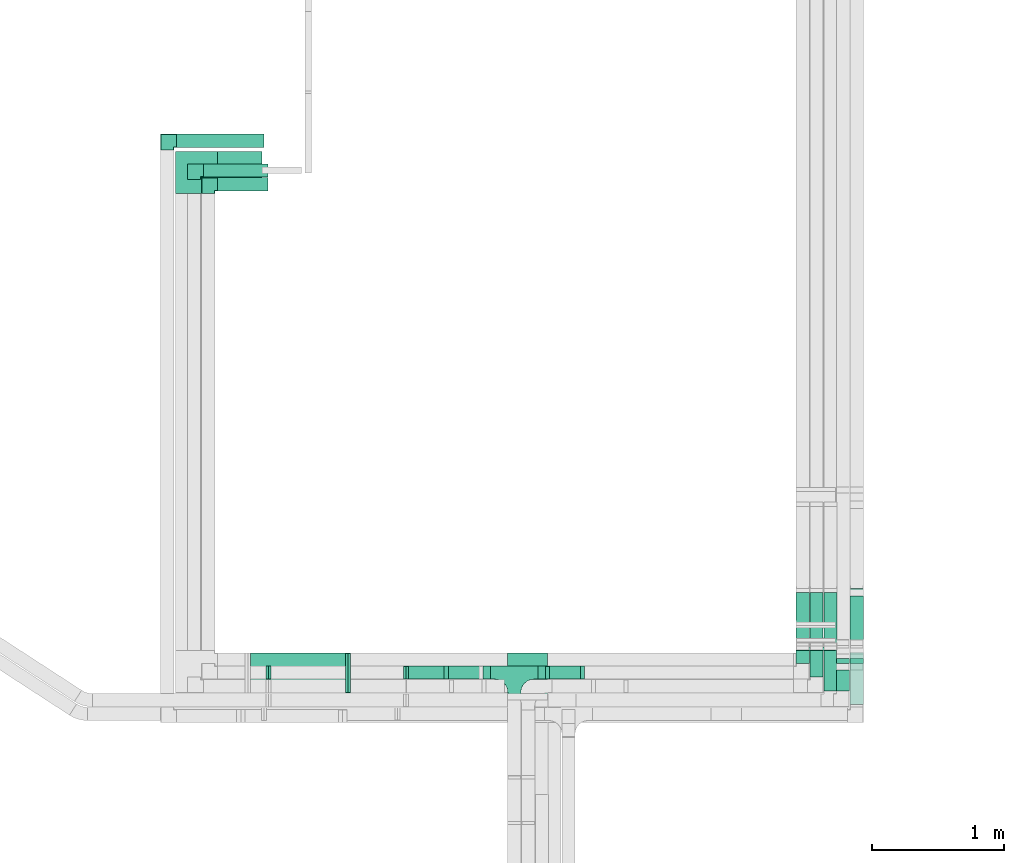
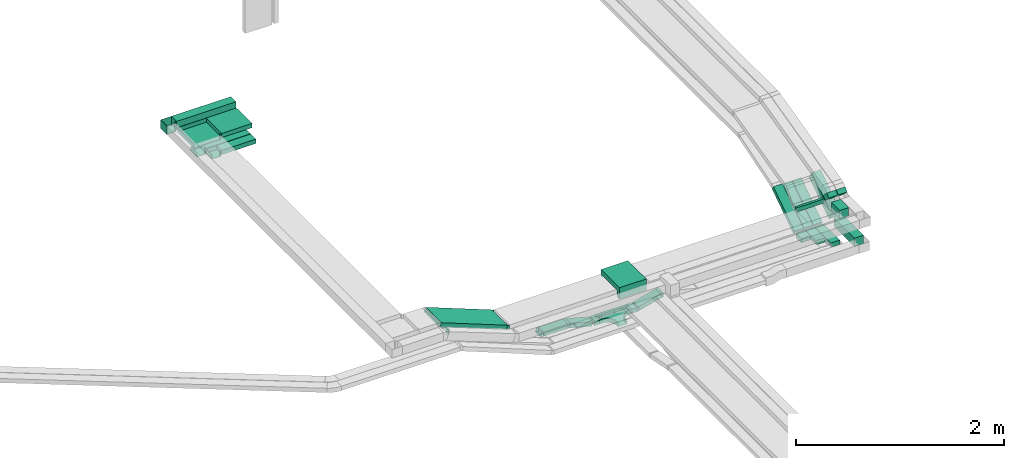
# One storey, part 6 of 14: 22 flow segments, 12 flow fittings.
"""IFC2X3 building model written with IfcOpenShell, lengths in millimetres."""

from ifc_helpers import new_model, entity, si_unit, converted_unit, derived_unit, direction, frame, frame_2d, origin, origin_2d_with_axis, place, context, subcontext, project, spatial, polyline, circle_curve, parameter, trimmed, segment, composite_curve, rectangle, outline, extrude, faceted_brep, source, transform, mapped, material, material_list, type_object, type_shapes, element, save


model = new_model("IFC2X3")

# Units and contexts
model_context = context("Model", 3, precision=0.01, world=origin(), true_north=direction((6.12303176911189e-17, 1.0)))
body_context = subcontext(model_context, "Body", "Model", "MODEL_VIEW")
ifc_project = project(units=[si_unit("LENGTHUNIT", "METRE", prefix="MILLI"), si_unit("AREAUNIT", "SQUARE_METRE"), si_unit("VOLUMEUNIT", "CUBIC_METRE"), converted_unit("PLANEANGLEUNIT", "DEGREE", entity("IfcRatioMeasure", 0.0174532925199433), si_unit("PLANEANGLEUNIT", "RADIAN"), dimensions=[0, 0, 0, 0, 0, 0, 0]), si_unit("MASSUNIT", "GRAM", prefix="KILO"), derived_unit("MASSDENSITYUNIT", [(si_unit("MASSUNIT", "GRAM", prefix="KILO"), 1), (si_unit("LENGTHUNIT", "METRE"), -3)]), derived_unit("MOMENTOFINERTIAUNIT", [(si_unit("LENGTHUNIT", "METRE"), 4)]), si_unit("TIMEUNIT", "SECOND"), si_unit("FREQUENCYUNIT", "HERTZ"), si_unit("THERMODYNAMICTEMPERATUREUNIT", "DEGREE_CELSIUS"), derived_unit("THERMALTRANSMITTANCEUNIT", [(si_unit("MASSUNIT", "GRAM", prefix="KILO"), 1), (si_unit("THERMODYNAMICTEMPERATUREUNIT", "KELVIN"), -1), (si_unit("TIMEUNIT", "SECOND"), -3)]), derived_unit("VOLUMETRICFLOWRATEUNIT", [(si_unit("LENGTHUNIT", "METRE"), 3), (si_unit("TIMEUNIT", "SECOND"), -1)]), derived_unit("MASSFLOWRATEUNIT", [(si_unit("MASSUNIT", "GRAM", prefix="KILO"), 1), (si_unit("TIMEUNIT", "SECOND"), -1)]), derived_unit("ROTATIONALFREQUENCYUNIT", [(si_unit("TIMEUNIT", "SECOND"), -1)]), si_unit("ELECTRICCURRENTUNIT", "AMPERE"), si_unit("ELECTRICVOLTAGEUNIT", "VOLT"), si_unit("POWERUNIT", "WATT"), si_unit("FORCEUNIT", "NEWTON", prefix="KILO"), si_unit("ILLUMINANCEUNIT", "LUX"), si_unit("LUMINOUSFLUXUNIT", "LUMEN"), si_unit("LUMINOUSINTENSITYUNIT", "CANDELA"), derived_unit("USERDEFINED", [(si_unit("MASSUNIT", "GRAM", prefix="KILO"), -1), (si_unit("LENGTHUNIT", "METRE"), -2), (si_unit("TIMEUNIT", "SECOND"), 3), (si_unit("LUMINOUSFLUXUNIT", "LUMEN"), 1)]), derived_unit("LINEARVELOCITYUNIT", [(si_unit("LENGTHUNIT", "METRE"), 1), (si_unit("TIMEUNIT", "SECOND"), -1)]), si_unit("PRESSUREUNIT", "PASCAL"), derived_unit("USERDEFINED", [(si_unit("LENGTHUNIT", "METRE"), -2), (si_unit("MASSUNIT", "GRAM", prefix="KILO"), 1), (si_unit("TIMEUNIT", "SECOND"), -2)]), derived_unit("LINEARFORCEUNIT", [(si_unit("MASSUNIT", "GRAM", prefix="KILO"), 1), (si_unit("LENGTHUNIT", "METRE"), 1), (si_unit("TIMEUNIT", "SECOND"), -2), (si_unit("LENGTHUNIT", "METRE"), -1)]), derived_unit("PLANARFORCEUNIT", [(si_unit("MASSUNIT", "GRAM", prefix="KILO"), 1), (si_unit("LENGTHUNIT", "METRE"), 1), (si_unit("TIMEUNIT", "SECOND"), -2), (si_unit("LENGTHUNIT", "METRE"), -2)])], contexts=[model_context])

# Site, building, storey
site_placement = place(None, origin())
site = spatial("IfcSite", under=ifc_project, at=site_placement, CompositionType="ELEMENT")
building_placement = place(site_placement, origin())
building = spatial("IfcBuilding", under=site, at=building_placement, CompositionType="ELEMENT")
storey_placement = place(building_placement, frame((0.0, 0.0, 19800.0)))
storey = spatial("IfcBuildingStorey", under=building, at=storey_placement, CompositionType="ELEMENT", Elevation=19800.0)

# Flow segments
cable_carrier_segment_type = type_object("IfcCableCarrierSegmentType", PredefinedType="CABLETRAYSEGMENT")
flow_segment_1_placement = place(storey_placement, frame((17256.59, 10152.84, 2600.0)))
element("IfcFlowSegment", 1, at=flow_segment_1_placement, inside=storey, type_object=cable_carrier_segment_type, context=body_context, shape_type="SweptSolid", body=[
    extrude(rectangle(XDim=269.725224847366, YDim=99.9999999999989, at=origin_2d_with_axis()), frame((134.86, 50.0, 0.0)), (0.0, 0.0, 1.0), 49.9999999999973),
])
flow_segment_2_placement = place(storey_placement, frame((20600.22, 9960.23, 2600.0)))
element("IfcFlowSegment", 2, at=flow_segment_2_placement, inside=storey, type_object=cable_carrier_segment_type, context=body_context, shape_type="SweptSolid", body=[
    extrude(rectangle(XDim=396.146721820888, YDim=100.000000000003, at=origin_2d_with_axis()), frame((50.0, 198.07, 0.0), z_axis=(0.0, 0.0, 1.0), x_axis=(0.0, 1.0, 0.0)), (0.0, 0.0, 1.0), 99.9999999999989),
])
flow_segment_3_placement = place(storey_placement, frame((20600.22, 10396.27, 2629.3)))
element("IfcFlowSegment", 3, at=flow_segment_3_placement, inside=storey, type_object=cable_carrier_segment_type, context=body_context, shape_type="SweptSolid", body=[
    extrude(rectangle(XDim=100.000000000001, YDim=467.368346274404, at=frame_2d((0.0, 0.0), x_axis=(0.0, 1.0))), frame((0.0, 221.69, 172.13), z_axis=(1.0, 0.0, 0.0), x_axis=(0.0, 0.829037572555048, 0.559192903470738)), (0.0, 0.0, 1.0), 100.000000000003),
])
flow_segment_4_placement = place(storey_placement, frame((20400.22, 10064.24, 2600.0)))
element("IfcFlowSegment", 4, at=flow_segment_4_placement, inside=storey, type_object=cable_carrier_segment_type, context=body_context, shape_type="SweptSolid", body=[
    extrude(rectangle(XDim=311.24039895918, YDim=100.000000000003, at=origin_2d_with_axis()), frame((50.0, 155.62, 0.0), z_axis=(0.0, 0.0, 1.0), x_axis=(0.0, -1.0, 0.0)), (0.0, 0.0, 1.0), 50.0000000000016),
])
flow_segment_5_placement = place(storey_placement, frame((20400.22, 10401.4, 2616.47)))
element("IfcFlowSegment", 5, at=flow_segment_5_placement, inside=storey, type_object=cable_carrier_segment_type, context=body_context, shape_type="SweptSolid", body=[
    extrude(rectangle(XDim=49.9999999999964, YDim=493.947448455053, at=frame_2d((0.0, 0.0), x_axis=(0.0, 1.0))), frame((0.0, 218.73, 158.83), z_axis=(1.0, 0.0, 0.0), x_axis=(0.0, 0.829037572555015, 0.559192903470787)), (0.0, 0.0, 1.0), 100.000000000003),
])
flow_segment_6_placement = place(storey_placement, frame((20295.22, 10401.4, 2616.47)))
element("IfcFlowSegment", 6, at=flow_segment_6_placement, inside=storey, type_object=cable_carrier_segment_type, context=body_context, shape_type="SweptSolid", body=[
    extrude(rectangle(XDim=49.9999999999977, YDim=493.947448455056, at=frame_2d((0.0, 0.0), x_axis=(0.0, 1.0))), frame((0.0, 218.73, 158.83), z_axis=(1.0, 0.0, 0.0), x_axis=(0.0, 0.829037572555018, 0.559192903470783)), (0.0, 0.0, 1.0), 100.000000000003),
])
flow_segment_7_placement = place(storey_placement, frame((20190.22, 10401.4, 2616.47)))
element("IfcFlowSegment", 7, at=flow_segment_7_placement, inside=storey, type_object=cable_carrier_segment_type, context=body_context, shape_type="SweptSolid", body=[
    extrude(rectangle(XDim=49.9999999999964, YDim=493.947448455053, at=frame_2d((0.0, 0.0), x_axis=(0.0, 1.0))), frame((0.0, 218.73, 158.83), z_axis=(1.0, 0.0, 0.0), x_axis=(0.0, 0.829037572555015, 0.559192903470787)), (0.0, 0.0, 1.0), 100.000000000003),
])
flow_segment_8_placement = place(storey_placement, frame((20295.22, 10169.82, 2600.0)))
element("IfcFlowSegment", 8, at=flow_segment_8_placement, inside=storey, type_object=cable_carrier_segment_type, context=body_context, shape_type="SweptSolid", body=[
    extrude(rectangle(XDim=205.655049876662, YDim=100.000000000003, at=origin_2d_with_axis()), frame((50.0, 102.83, 0.0), z_axis=(0.0, 0.0, 1.0), x_axis=(0.0, -1.0, 0.0)), (0.0, 0.0, 1.0), 49.999999999993),
])
flow_segment_9_placement = place(storey_placement, frame((20190.22, 10272.84, 2600.0)))
element("IfcFlowSegment", 9, at=flow_segment_9_placement, inside=storey, type_object=cable_carrier_segment_type, context=body_context, shape_type="SweptSolid", body=[
    extrude(rectangle(XDim=102.633638913558, YDim=100.000000000003, at=origin_2d_with_axis()), frame((50.0, 51.32, 0.0), z_axis=(0.0, 0.0, 1.0), x_axis=(0.0, 1.0, 0.0)), (0.0, 0.0, 1.0), 49.9999999999973),
])
flow_segment_10_placement = place(storey_placement, frame((20600.22, 10271.78, 2948.93)))
element("IfcFlowSegment", 10, at=flow_segment_10_placement, inside=storey, type_object=cable_carrier_segment_type, context=body_context, shape_type="SweptSolid", body=[
    extrude(rectangle(XDim=53.3220562203544, YDim=99.999999999999, at=origin_2d_with_axis()), frame((0.0, 54.21, 54.21), z_axis=(1.0, 0.0, 0.0), x_axis=(0.0, -0.707106781186487, -0.707106781186608)), (0.0, 0.0, 1.0), 100.000000000003),
])
flow_segment_11_placement = place(storey_placement, frame((20495.22, 10064.24, 2900.0)))
element("IfcFlowSegment", 11, at=flow_segment_11_placement, inside=storey, type_object=cable_carrier_segment_type, context=body_context, shape_type="SweptSolid", body=[
    extrude(rectangle(XDim=160.114335996502, YDim=100.000000000003, at=origin_2d_with_axis()), frame((50.0, 80.06, 0.0), z_axis=(0.0, 0.0, 1.0), x_axis=(0.0, 1.0, 0.0)), (0.0, 0.0, 1.0), 100.000000000003),
])
flow_segment_12_placement = place(storey_placement, frame((20190.22, 10370.13, 2900.0)))
element("IfcFlowSegment", 12, at=flow_segment_12_placement, inside=storey, type_object=cable_carrier_segment_type, context=body_context, shape_type="SweptSolid", body=[
    extrude(rectangle(XDim=28.3940759827228, YDim=300.000000000001, at=origin_2d_with_axis()), frame((150.0, 14.2, 0.0), z_axis=(0.0, 0.0, 1.0), x_axis=(0.0, -1.0, 0.0)), (0.0, 0.0, 1.0), 49.999999999993),
])
flow_segment_13_placement = place(storey_placement, frame((20495.22, 10271.78, 2948.93)))
element("IfcFlowSegment", 13, at=flow_segment_13_placement, inside=storey, type_object=cable_carrier_segment_type, context=body_context, shape_type="SweptSolid", body=[
    extrude(rectangle(XDim=53.322056220356, YDim=100.000000000002, at=origin_2d_with_axis()), frame((0.0, 54.21, 54.21), z_axis=(1.0, 0.0, 0.0), x_axis=(0.0, -0.707106781186507, -0.707106781186588)), (0.0, 0.0, 1.0), 100.000000000008),
])
flow_segment_14_placement = place(storey_placement, frame((18310.63, 10152.84, 2531.55)))
element("IfcFlowSegment", 14, at=flow_segment_14_placement, inside=storey, type_object=cable_carrier_segment_type, context=body_context, shape_type="SweptSolid", body=[
    extrude(rectangle(XDim=49.9999999999963, YDim=99.9999999999989, at=origin_2d_with_axis()), frame((6.47, 50.0, 24.15), z_axis=(0.965925826289085, 0.0, 0.258819045102459), x_axis=(-0.258819045102459, 0.0, 0.965925826289085)), (0.0, 0.0, 1.0), 255.518225265326),
])
flow_segment_15_placement = place(storey_placement, frame((18237.14, 10152.84, 2527.53)))
element("IfcFlowSegment", 15, at=flow_segment_15_placement, inside=storey, type_object=cable_carrier_segment_type, context=body_context, shape_type="SweptSolid", body=[
    extrude(rectangle(XDim=55.8887887634152, YDim=99.9999999999989, at=origin_2d_with_axis()), frame((27.94, 50.0, 0.0), z_axis=(0.0, 0.0, 1.0), x_axis=(-1.0, 0.0, 0.0)), (0.0, 0.0, 1.0), 49.9999999999973),
])
flow_segment_16_placement = place(storey_placement, frame((17543.91, 10152.84, 2531.55)))
element("IfcFlowSegment", 16, at=flow_segment_16_placement, inside=storey, type_object=cable_carrier_segment_type, context=body_context, shape_type="SweptSolid", body=[
    extrude(rectangle(XDim=49.9999999999963, YDim=99.9999999999989, at=frame_2d((0.0, 0.0), x_axis=(0.0, 1.0))), frame((6.47, 50.0, 90.28), z_axis=(0.965925826289085, 0.0, -0.258819045102459), x_axis=(0.0, 1.0, 0.0)), (0.0, 0.0, 1.0), 255.518225265326),
])
flow_segment_17_placement = place(storey_placement, frame((17821.26, 10152.84, 2527.53)))
element("IfcFlowSegment", 17, at=flow_segment_17_placement, inside=storey, type_object=cable_carrier_segment_type, context=body_context, shape_type="SweptSolid", body=[
    extrude(rectangle(XDim=55.8887887635105, YDim=99.9999999999989, at=origin_2d_with_axis()), frame((27.94, 50.0, 0.0)), (0.0, 0.0, 1.0), 49.9999999999973),
])
flow_segment_18_placement = place(storey_placement, frame((16040.11, 10050.13, 2907.31)))
element("IfcFlowSegment", 18, at=flow_segment_18_placement, inside=storey, type_object=cable_carrier_segment_type, context=body_context, shape_type="SweptSolid", body=[
    extrude(rectangle(XDim=49.9999999999997, YDim=300.000000000001, at=frame_2d((0.0, 0.0), x_axis=(0.0, 1.0))), frame((9.1, 150.0, 312.1), z_axis=(0.931412677772554, 0.0, -0.36396486600297), x_axis=(0.0, 1.0, 0.0)), (0.0, 0.0, 1.0), 793.526444095363),
])
flow_segment_19_placement = place(storey_placement, frame((15810.0, 13850.13, 3200.0)))
element("IfcFlowSegment", 19, at=flow_segment_19_placement, inside=storey, type_object=cable_carrier_segment_type, context=body_context, shape_type="SweptSolid", body=[
    extrude(rectangle(XDim=337.305497573283, YDim=300.000000000001, at=origin_2d_with_axis()), frame((168.65, 150.0, 0.0)), (0.0, 0.0, 1.0), 49.9999999999973),
])
flow_segment_20_placement = place(storey_placement, frame((15498.62, 14180.23, 3200.0)))
element("IfcFlowSegment", 20, at=flow_segment_20_placement, inside=storey, type_object=cable_carrier_segment_type, context=body_context, shape_type="SweptSolid", body=[
    extrude(rectangle(XDim=661.375838147948, YDim=99.9999999999989, at=origin_2d_with_axis()), frame((330.69, 50.0, 0.0)), (0.0, 0.0, 1.0), 100.000000000003),
])
flow_segment_21_placement = place(storey_placement, frame((15810.0, 13850.13, 3000.0)))
element("IfcFlowSegment", 21, at=flow_segment_21_placement, inside=storey, type_object=cable_carrier_segment_type, context=body_context, shape_type="SweptSolid", body=[
    extrude(rectangle(XDim=381.506330110017, YDim=99.9999999999989, at=origin_2d_with_axis()), frame((190.75, 50.0, 0.0)), (0.0, 0.0, 1.0), 49.9999999999973),
])
flow_segment_22_placement = place(storey_placement, frame((15701.77, 13954.94, 3000.0)))
element("IfcFlowSegment", 22, at=flow_segment_22_placement, inside=storey, type_object=cable_carrier_segment_type, context=body_context, shape_type="SweptSolid", body=[
    extrude(rectangle(XDim=489.733815594426, YDim=99.9999999999989, at=origin_2d_with_axis()), frame((244.87, 50.0, 0.0)), (0.0, 0.0, 1.0), 49.9999999999973),
])

# Flow fittings
ifc_material = material()
cable_carrier_fitting_type_1 = type_object("IfcCableCarrierFittingType", PredefinedType="NOTDEFINED", material=ifc_material)
shared_shape_1 = source(origin(), body_context, "Body", "Brep", [
    faceted_brep([(-53.41, -124.12, 25.0), (-50.0, -150.0, 25.0), (-50.0, -180.0, 25.0), (-49.2, -180.0, 25.0), (-49.2, -150.0, 25.0), (-52.63, -123.91, 25.0), (-62.7, -99.6, 25.0), (-78.72, -78.72, 25.0), (-99.6, -62.7, 25.0), (-123.91, -52.63, 25.0), (-150.0, -49.2, 25.0), (-180.0, -49.2, 25.0), (-180.0, -50.0, 25.0), (-150.0, -50.0, 25.0), (-124.12, -53.41, 25.0), (-100.0, -63.4, 25.0), (-79.29, -79.29, 25.0), (-63.4, -100.0, 25.0), (180.0, -50.0, 25.0), (180.0, -49.2, 25.0), (150.0, -49.2, 25.0), (123.91, -52.63, 25.0), (99.6, -62.7, 25.0), (78.72, -78.72, 25.0), (62.7, -99.6, 25.0), (52.63, -123.91, 25.0), (49.2, -150.0, 25.0), (49.2, -180.0, 25.0), (50.0, -180.0, 25.0), (50.0, -150.0, 25.0), (53.41, -124.12, 25.0), (63.4, -100.0, 25.0), (79.29, -79.29, 25.0), (100.0, -63.4, 25.0), (124.12, -53.41, 25.0), (150.0, -50.0, 25.0), (180.0, 49.2, 25.0), (180.0, 50.0, 25.0), (-180.0, 50.0, 25.0), (-180.0, 49.2, 25.0), (-180.0, -50.0, -25.0), (-180.0, 50.0, -25.0), (180.0, 50.0, -25.0), (180.0, -50.0, -25.0), (150.0, -50.0, -25.0), (124.12, -53.41, -25.0), (100.0, -63.4, -25.0), (79.29, -79.29, -25.0), (63.4, -100.0, -25.0), (53.41, -124.12, -25.0), (50.0, -150.0, -25.0), (50.0, -180.0, -25.0), (-50.0, -180.0, -25.0), (-50.0, -150.0, -25.0), (-53.41, -124.12, -25.0), (-63.4, -100.0, -25.0), (-79.29, -79.29, -25.0), (-100.0, -63.4, -25.0), (-124.12, -53.41, -25.0), (-150.0, -50.0, -25.0), (-50.0, -150.0, -24.2), (49.2, -180.0, -24.2), (-49.2, -180.0, -24.2), (-49.2, -150.0, -24.2), (-150.0, -49.2, -24.2), (-180.0, -49.2, -24.2), (180.0, -49.2, -24.2), (150.0, -49.2, -24.2), (-180.0, 49.2, -24.2), (-150.0, -50.0, -24.2), (150.0, -50.0, -24.2), (180.0, 49.2, -24.2), (49.2, -150.0, -24.2), (50.0, -150.0, -24.2), (-123.91, -52.63, -24.2), (-99.6, -62.7, -24.2), (-78.72, -78.72, -24.2), (-62.7, -99.6, -24.2), (-52.63, -123.91, -24.2), (52.63, -123.91, -24.2), (62.7, -99.6, -24.2), (78.72, -78.72, -24.2), (99.6, -62.7, -24.2), (123.91, -52.63, -24.2)], [[[0, 1, 2, 3, 4, 5, 6, 7, 8, 9, 10, 11, 12, 13, 14, 15, 16, 17]], [[18, 19, 20, 21, 22, 23, 24, 25, 26, 27, 28, 29, 30, 31, 32, 33, 34, 35]], [[36, 37, 38, 39]], [[40, 41, 42, 43, 44, 45, 46, 47, 48, 49, 50, 51, 52, 53, 54, 55, 56, 57, 58, 59]], [[2, 1, 60, 53, 52]], [[3, 2, 52, 51, 28, 27, 61, 62]], [[4, 3, 62, 63]], [[11, 10, 64, 65]], [[20, 19, 66, 67]], [[39, 38, 41, 40, 12, 11, 65, 68]], [[13, 12, 40, 59, 69]], [[18, 35, 70, 44, 43]], [[19, 18, 43, 42, 37, 36, 71, 66]], [[27, 26, 72, 61]], [[29, 28, 51, 50, 73]], [[38, 37, 42, 41]], [[36, 39, 68, 71]], [[68, 65, 64, 74, 75, 76, 77, 78, 63, 62, 61, 72, 79, 80, 81, 82, 83, 67, 66, 71]], [[14, 13, 69, 59, 58]], [[58, 57, 15, 14]], [[15, 57, 56, 16]], [[0, 17, 55, 54]], [[0, 54, 53, 60, 1]], [[55, 17, 16, 56]], [[5, 4, 63, 78]], [[6, 5, 78, 77]], [[7, 6, 77, 76]], [[8, 7, 76, 75]], [[9, 8, 75, 74]], [[10, 9, 74, 64]], [[21, 20, 67, 83]], [[22, 21, 83, 82]], [[23, 22, 82, 81]], [[81, 80, 24, 23]], [[24, 80, 79, 25]], [[79, 72, 26, 25]], [[30, 29, 73, 50, 49]], [[31, 30, 49, 48]], [[31, 48, 47, 32]], [[33, 32, 47, 46]], [[45, 34, 33, 46]], [[34, 45, 44, 70, 35]]]),
])
type_shapes(cable_carrier_fitting_type_1, [shared_shape_1])
flow_fitting_1_placement = place(storey_placement, frame((18057.14, 10202.84, 2552.53)))
element("IfcFlowFitting", 23, at=flow_fitting_1_placement, inside=storey, type_object=cable_carrier_fitting_type_1, material=ifc_material, Name="470_DKC_S5_T", context=body_context, shape_type="MappedRepresentation", body=[
    mapped(shared_shape_1, transform((0.0, 0.0, 0.0), scale=1.0)),
])
cable_carrier_fitting_type_2 = type_object("IfcCableCarrierFittingType", PredefinedType="NOTDEFINED", material=ifc_material)
shared_shape_2 = source(origin(), body_context, "Body", "Brep", [
    faceted_brep([(-70.0, 50.0, -25.0), (-70.0, -50.0, -25.0), (-70.0, -50.0, 25.0), (-70.0, -47.46, 25.0), (-70.0, -47.46, -22.46), (-70.0, 47.46, -22.46), (-70.0, 47.46, 25.0), (-70.0, 50.0, 25.0), (-50.0, 50.0, -25.0), (-50.0, 70.0, -25.0), (50.0, 70.0, -25.0), (50.0, -50.0, -25.0), (50.0, -50.0, 25.0), (50.0, 70.0, 25.0), (47.46, 70.0, 25.0), (47.46, -47.46, 25.0), (47.46, -47.46, -22.46), (47.46, 70.0, -22.46), (-47.46, 70.0, -22.46), (-47.46, 47.46, -22.46), (-47.46, 47.46, 25.0), (-47.46, 70.0, 25.0), (-50.0, 70.0, 25.0), (-50.0, 50.0, 25.0)], [[[0, 1, 2, 3, 4, 5, 6, 7]], [[1, 0, 8, 9, 10, 11]], [[2, 1, 11, 12]], [[3, 2, 12, 13, 14, 15]], [[4, 3, 15, 16]], [[5, 4, 16, 17, 18, 19]], [[6, 5, 19, 20]], [[7, 6, 20, 21, 22, 23]], [[0, 7, 23, 8]], [[9, 22, 21, 18, 17, 14, 13, 10]], [[12, 11, 10, 13]], [[16, 15, 14, 17]], [[20, 19, 18, 21]], [[8, 23, 22, 9]]]),
])
type_shapes(cable_carrier_fitting_type_2, [shared_shape_2])
for number, where, z_axis, x_axis in (
    (24, (15740.0, 13900.13, 3025.0), (0.0, 0.0, 1.0), (-1.0, 0.0, 0.0)),
    (25, (15631.77, 14004.94, 3025.0), (0.0, 0.0, 1.0), (-1.0, 0.0, 0.0)),
):
    element("IfcFlowFitting", number, at=place(storey_placement, frame(where, z_axis=z_axis, x_axis=x_axis)), inside=storey, type_object=cable_carrier_fitting_type_2, material=ifc_material, context=body_context, shape_type="MappedRepresentation", body=[
        mapped(shared_shape_2, transform((0.0, 0.0, 0.0), scale=1.0)),
    ])
cable_carrier_fitting_type_3 = type_object("IfcCableCarrierFittingType", PredefinedType="NOTDEFINED", material=ifc_material)
shared_shape_3 = source(origin(), body_context, "Body", "Brep", [
    faceted_brep([(-170.0, 150.0, -25.0), (-170.0, -150.0, -25.0), (-170.0, -150.0, 25.0), (-170.0, -147.46, 25.0), (-170.0, -147.46, -22.46), (-170.0, 147.46, -22.46), (-170.0, 147.46, 25.0), (-170.0, 150.0, 25.0), (-150.0, 150.0, -25.0), (-150.0, 170.0, -25.0), (150.0, 170.0, -25.0), (150.0, -150.0, -25.0), (150.0, -150.0, 25.0), (150.0, 170.0, 25.0), (147.46, 170.0, 25.0), (147.46, -147.46, 25.0), (147.46, -147.46, -22.46), (147.46, 170.0, -22.46), (-147.46, 170.0, -22.46), (-147.46, 147.46, -22.46), (-147.46, 147.46, 25.0), (-147.46, 170.0, 25.0), (-150.0, 170.0, 25.0), (-150.0, 150.0, 25.0)], [[[0, 1, 2, 3, 4, 5, 6, 7]], [[1, 0, 8, 9, 10, 11]], [[2, 1, 11, 12]], [[3, 2, 12, 13, 14, 15]], [[4, 3, 15, 16]], [[5, 4, 16, 17, 18, 19]], [[6, 5, 19, 20]], [[7, 6, 20, 21, 22, 23]], [[0, 7, 23, 8]], [[9, 22, 21, 18, 17, 14, 13, 10]], [[12, 11, 10, 13]], [[16, 15, 14, 17]], [[20, 19, 18, 21]], [[8, 23, 22, 9]]]),
])
type_shapes(cable_carrier_fitting_type_3, [shared_shape_3])
flow_fitting_2_placement = place(storey_placement, frame((15640.0, 14000.13, 3225.0), z_axis=(0.0, 0.0, 1.0), x_axis=(-1.0, 0.0, 0.0)))
element("IfcFlowFitting", 26, at=flow_fitting_2_placement, inside=storey, type_object=cable_carrier_fitting_type_3, material=ifc_material, context=body_context, shape_type="MappedRepresentation", body=[
    mapped(shared_shape_3, transform((0.0, 0.0, 0.0), scale=1.0)),
])
cable_carrier_fitting_type_4 = type_object("IfcCableCarrierFittingType", PredefinedType="NOTDEFINED", material=ifc_material)
shared_shape_4 = source(origin(), body_context, "Body", "Brep", [
    faceted_brep([(-70.0, 50.0, -50.0), (-70.0, -50.0, -50.0), (-70.0, -50.0, 50.0), (-70.0, -47.46, 50.0), (-70.0, -47.46, -47.46), (-70.0, 47.46, -47.46), (-70.0, 47.46, 50.0), (-70.0, 50.0, 50.0), (-50.0, 50.0, -50.0), (-50.0, 70.0, -50.0), (50.0, 70.0, -50.0), (50.0, -50.0, -50.0), (50.0, -50.0, 50.0), (50.0, 70.0, 50.0), (47.46, 70.0, 50.0), (47.46, -47.46, 50.0), (47.46, -47.46, -47.46), (47.46, 70.0, -47.46), (-47.46, 70.0, -47.46), (-47.46, 47.46, -47.46), (-47.46, 47.46, 50.0), (-47.46, 70.0, 50.0), (-50.0, 70.0, 50.0), (-50.0, 50.0, 50.0)], [[[0, 1, 2, 3, 4, 5, 6, 7]], [[1, 0, 8, 9, 10, 11]], [[2, 1, 11, 12]], [[3, 2, 12, 13, 14, 15]], [[4, 3, 15, 16]], [[5, 4, 16, 17, 18, 19]], [[6, 5, 19, 20]], [[7, 6, 20, 21, 22, 23]], [[0, 7, 23, 8]], [[9, 22, 21, 18, 17, 14, 13, 10]], [[12, 11, 10, 13]], [[16, 15, 14, 17]], [[20, 19, 18, 21]], [[8, 23, 22, 9]]]),
])
type_shapes(cable_carrier_fitting_type_4, [shared_shape_4])
flow_fitting_3_placement = place(storey_placement, frame((15428.62, 14230.23, 3250.0), z_axis=(0.0, 0.0, 1.0), x_axis=(-1.0, 0.0, 0.0)))
element("IfcFlowFitting", 27, at=flow_fitting_3_placement, inside=storey, type_object=cable_carrier_fitting_type_4, material=ifc_material, context=body_context, shape_type="MappedRepresentation", body=[
    mapped(shared_shape_4, transform((0.0, 0.0, 0.0), scale=1.0)),
])
cable_carrier_fitting_type_5 = type_object("IfcCableCarrierFittingType", PredefinedType="NOTDEFINED", material=ifc_material)
shared_shape_5 = source(origin(), body_context, "Body", "Brep", [
    faceted_brep([(-15.12, -25.0, 50.0), (-15.12, 25.0, 50.0), (-15.12, 25.0, 47.46), (-15.12, -22.46, 47.46), (-15.12, -22.46, -47.46), (-15.12, 25.0, -47.46), (-15.12, 25.0, -50.0), (-15.12, -25.0, -50.0), (23.03, -17.98, 50.0), (23.03, -17.98, -50.0), (5.23, 28.75, -50.0), (5.23, 28.75, -47.46), (22.13, -15.61, -47.46), (22.13, -15.61, 47.46), (5.23, 28.75, 47.46), (5.23, 28.75, 50.0), (4.6, -25.0, 50.0), (-4.6, 25.0, 50.0), (-4.6, 25.0, 47.46), (4.13, -22.46, 47.46), (4.13, -22.46, -47.46), (-4.6, 25.0, -47.46), (-4.6, 25.0, -50.0), (4.6, -25.0, -50.0)], [[[0, 1, 2, 3, 4, 5, 6, 7]], [[8, 9, 10, 11, 12, 13, 14, 15]], [[1, 0, 16, 8, 15, 17]], [[2, 1, 17, 18]], [[3, 2, 18, 14, 13, 19]], [[4, 3, 19, 20]], [[5, 4, 20, 12, 11, 21]], [[6, 5, 21, 22]], [[7, 6, 22, 10, 9, 23]], [[0, 7, 23, 16]], [[18, 17, 15, 14]], [[20, 19, 13, 12]], [[22, 21, 11, 10]], [[16, 23, 9, 8]]]),
])
type_shapes(cable_carrier_fitting_type_5, [shared_shape_5])
for number, where, z_axis, x_axis in (
    (28, (17241.47, 10202.84, 2625.0), (0.0, -1.0, 0.0), (0.934483298097407, 0.0, -0.356006974056678)),
    (29, (16191.51, 10202.84, 3025.0), (0.0, -1.0, 0.0), (-0.934483298097407, 0.0, 0.356006974056678)),
):
    element("IfcFlowFitting", number, at=place(storey_placement, frame(where, z_axis=z_axis, x_axis=x_axis)), inside=storey, type_object=cable_carrier_fitting_type_5, material=ifc_material, context=body_context, shape_type="MappedRepresentation", body=[
        mapped(shared_shape_5, transform((0.0, 0.0, 0.0), scale=1.0)),
    ])
cable_carrier_fitting_type_6 = type_object("IfcCableCarrierFittingType", PredefinedType="NOTDEFINED", material=ifc_material)
shared_shape_6 = source(origin(), body_context, "Body", "Brep", [
    faceted_brep([(-12.24, -25.0, 50.0), (-12.24, 25.0, 50.0), (-12.24, 25.0, 47.46), (-12.24, -22.46, 47.46), (-12.24, -22.46, -47.46), (-12.24, 25.0, -47.46), (-12.24, 25.0, -50.0), (-12.24, -25.0, -50.0), (18.29, -20.98, 50.0), (18.29, -20.98, -50.0), (5.35, 27.32, -50.0), (5.35, 27.32, -47.46), (17.64, -18.53, -47.46), (17.64, -18.53, 47.46), (5.35, 27.32, 47.46), (5.35, 27.32, 50.0), (3.29, -25.0, 50.0), (-3.29, 25.0, 50.0), (-3.29, 25.0, 47.46), (2.96, -22.46, 47.46), (2.96, -22.46, -47.46), (-3.29, 25.0, -47.46), (-3.29, 25.0, -50.0), (3.29, -25.0, -50.0)], [[[0, 1, 2, 3, 4, 5, 6, 7]], [[8, 9, 10, 11, 12, 13, 14, 15]], [[1, 0, 16, 8, 15, 17]], [[2, 1, 17, 18]], [[3, 2, 18, 14, 13, 19]], [[4, 3, 19, 20]], [[5, 4, 20, 12, 11, 21]], [[6, 5, 21, 22]], [[7, 6, 22, 10, 9, 23]], [[0, 7, 23, 16]], [[18, 17, 15, 14]], [[20, 19, 13, 12]], [[22, 21, 11, 10]], [[16, 23, 9, 8]]]),
])
type_shapes(cable_carrier_fitting_type_6, [shared_shape_6])
for number, where, z_axis, x_axis in (
    (30, (18575.73, 10202.84, 2625.0), (0.0, -1.0, 0.0), (-1.0, 0.0, 0.0)),
    (31, (18305.27, 10202.84, 2552.53), (0.0, 1.0, 0.0), (-0.965925826289095, 0.0, -0.258819045102422)),
    (32, (17538.56, 10202.84, 2625.0), (0.0, -1.0, 0.0), (-0.965925826289095, 0.0, 0.258819045102422)),
):
    element("IfcFlowFitting", number, at=place(storey_placement, frame(where, z_axis=z_axis, x_axis=x_axis)), inside=storey, type_object=cable_carrier_fitting_type_6, material=ifc_material, context=body_context, shape_type="MappedRepresentation", body=[
        mapped(shared_shape_6, transform((0.0, 0.0, 0.0), scale=1.0)),
    ])
cable_carrier_fitting_type_7 = type_object("IfcCableCarrierFittingType", PredefinedType="NOTDEFINED", material=ifc_material)
shared_shape_7 = source(origin(), body_context, "Body", "Brep", [
    faceted_brep([(-15.36, -25.0, 150.0), (-15.36, 25.0, 150.0), (-15.36, 25.0, 147.46), (-15.36, -22.46, 147.46), (-15.36, -22.46, -147.46), (-15.36, 25.0, -147.46), (-15.36, 25.0, -150.0), (-15.36, -25.0, -150.0), (23.41, -17.69, 150.0), (23.41, -17.69, -150.0), (5.21, 28.88, -150.0), (5.21, 28.88, -147.46), (22.49, -15.33, -147.46), (22.49, -15.33, 147.46), (5.21, 28.88, 147.46), (5.21, 28.88, 150.0), (4.71, -25.0, 150.0), (-4.71, 25.0, 150.0), (-4.71, 25.0, 147.46), (4.23, -22.46, 147.46), (4.23, -22.46, -147.46), (-4.71, 25.0, -147.46), (-4.71, 25.0, -150.0), (4.71, -25.0, -150.0)], [[[0, 1, 2, 3, 4, 5, 6, 7]], [[8, 9, 10, 11, 12, 13, 14, 15]], [[1, 0, 16, 8, 15, 17]], [[2, 1, 17, 18]], [[3, 2, 18, 14, 13, 19]], [[4, 3, 19, 20]], [[5, 4, 20, 12, 11, 21]], [[6, 5, 21, 22]], [[7, 6, 22, 10, 9, 23]], [[0, 7, 23, 16]], [[18, 17, 15, 14]], [[20, 19, 13, 12]], [[22, 21, 11, 10]], [[16, 23, 9, 8]]]),
])
type_shapes(cable_carrier_fitting_type_7, [shared_shape_7])
flow_fitting_4_placement = place(storey_placement, frame((16802.62, 10200.13, 2925.0), z_axis=(0.0, -1.0, 0.0), x_axis=(0.931412677772567, 0.0, -0.363964866002938)))
element("IfcFlowFitting", 33, at=flow_fitting_4_placement, inside=storey, type_object=cable_carrier_fitting_type_7, material=ifc_material, context=body_context, shape_type="MappedRepresentation", body=[
    mapped(shared_shape_7, transform((0.0, 0.0, 0.0), scale=1.0)),
])
ifc_material_list = material_list([ifc_material, ifc_material, ifc_material, ifc_material, ifc_material])
cable_carrier_fitting_type_8 = type_object("IfcCableCarrierFittingType", PredefinedType="NOTDEFINED", material=ifc_material_list)
shared_shape_8 = source(origin(), body_context, "Body", "SweptSolid", [
    extrude(outline(composite_curve([segment(polyline([(-61.86, -231.43), (-7.86, -231.43)]), True, "CONTINUOUS"), segment(polyline([(-7.86, -231.43), (-7.86, 68.57)]), True, "CONTINUOUS"), segment(trimmed(circle_curve(frame_2d((-2.86, 68.57), x_axis=(0.0, -1.0)), 5.0), [parameter(180.0)], [parameter(270.0)], True, "PARAMETER"), False, "CONTINUOUS"), segment(polyline([(-2.86, 73.57), (71.14, 73.57)]), True, "CONTINUOUS"), segment(polyline([(71.14, 73.57), (71.14, 123.57)]), True, "CONTINUOUS"), segment(polyline([(71.14, 123.57), (-61.86, 123.57)]), True, "CONTINUOUS"), segment(polyline([(-61.86, 123.57), (-61.86, -231.43)]), True, "CONTINUOUS")], self_intersect=False)), frame((-81.43, -150.0, 17.14), z_axis=(0.0, 1.0, 0.0), x_axis=(0.0, 0.0, -1.0)), (0.0, 0.0, 1.0), 0.799999999999987),
    extrude(rectangle(XDim=0.799999999999852, YDim=300.0, at=origin_2d_with_axis()), frame((149.6, 0.0, -7.5), z_axis=(0.0, 0.0, 1.0), x_axis=(-1.0, 0.0, 0.0)), (0.0, 0.0, 1.0), 86.4999999999327),
    extrude(rectangle(XDim=355.0, YDim=300.0, at=origin_2d_with_axis()), frame((-27.5, 0.0, 78.2), z_axis=(0.0, 0.0, 1.0), x_axis=(-1.0, 0.0, 0.0)), (0.0, 0.0, 1.0), 0.800000000000055),
    extrude(rectangle(XDim=0.79999999999992, YDim=298.4, at=origin_2d_with_axis()), frame((-204.6, 0.0, -54.0), z_axis=(0.0, 0.0, 1.0), x_axis=(-1.0, 0.0, 0.0)), (0.0, 0.0, 1.0), 132.999999999999),
    extrude(outline(composite_curve([segment(polyline([(-61.86, -231.43), (-7.86, -231.43)]), True, "CONTINUOUS"), segment(polyline([(-7.86, -231.43), (-7.86, 68.57)]), True, "CONTINUOUS"), segment(trimmed(circle_curve(frame_2d((-2.86, 68.57), x_axis=(0.0, -1.0)), 5.0), [parameter(180.0)], [parameter(270.0)], True, "PARAMETER"), False, "CONTINUOUS"), segment(polyline([(-2.86, 73.57), (71.14, 73.57)]), True, "CONTINUOUS"), segment(polyline([(71.14, 73.57), (71.14, 123.57)]), True, "CONTINUOUS"), segment(polyline([(71.14, 123.57), (-61.86, 123.57)]), True, "CONTINUOUS"), segment(polyline([(-61.86, 123.57), (-61.86, -231.43)]), True, "CONTINUOUS")], self_intersect=False)), frame((-81.43, 149.2, 17.14), z_axis=(0.0, 1.0, 0.0), x_axis=(0.0, 0.0, -1.0)), (0.0, 0.0, 1.0), 0.799999999999784),
])
type_shapes(cable_carrier_fitting_type_8, [shared_shape_8])
flow_fitting_5_placement = place(storey_placement, frame((18157.14, 10200.13, 2925.0), z_axis=(0.0, 0.0, 1.0), x_axis=(0.0, 1.0, 0.0)))
element("IfcFlowFitting", 34, at=flow_fitting_5_placement, inside=storey, type_object=cable_carrier_fitting_type_8, material=ifc_material_list, Name="470_DKC_S5_vertical T-shaped cover", context=body_context, shape_type="MappedRepresentation", body=[
    mapped(shared_shape_8, transform((0.0, 0.0, 0.0), scale=1.0)),
])

save(model, "model.ifc")
